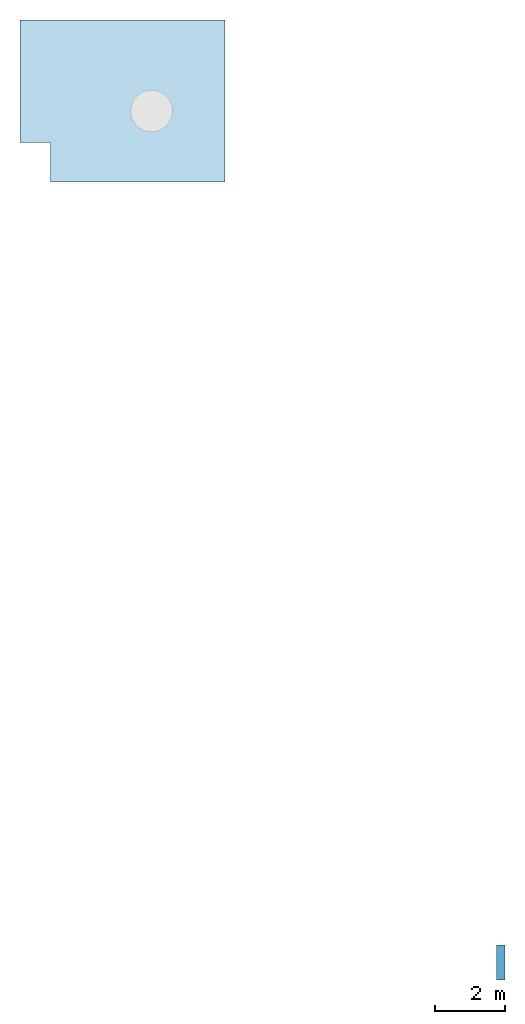
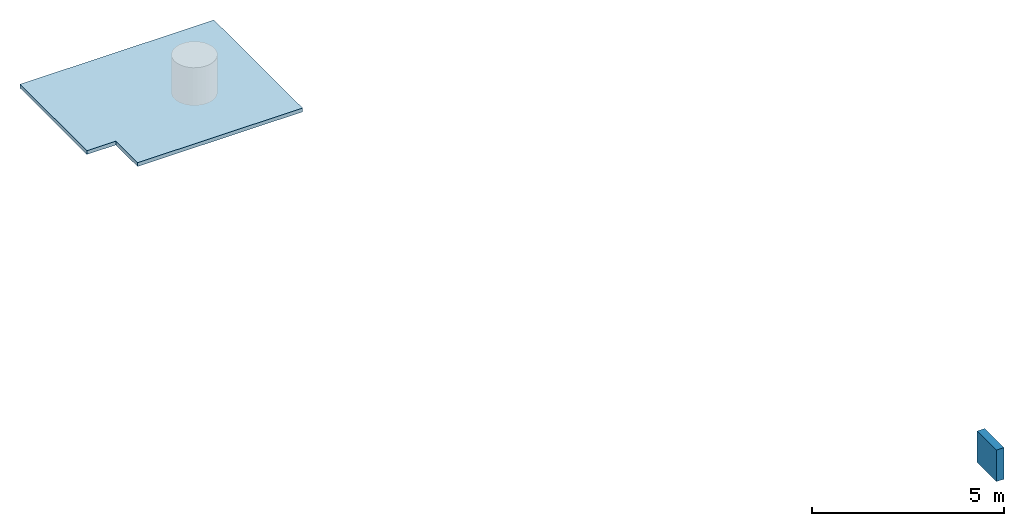
# One storey, part 1 of 2: 1 slab, 1 wall.
"""IFC4X3_ADD2 building model written with IfcOpenShell, lengths in metres."""

import ifcopenshell
import ifcopenshell.guid

model = None  # the IFC model being written
_history = None  # IfcOwnerHistory: only IFC2X3 demands one
_inside = {}  # id of a spatial element -> (the spatial element, [elements in it])
_under = {}  # id of a project, library or spatial element -> (it, [spatial elements below it])
_declared = {}  # id of a project -> (the project, [libraries it declares])
_typed = {}  # id of a type object -> (the type object, [elements of that type])
_made_of = {}  # id of a material, layer set ... -> (it, [elements and type objects made of it])


def new_model(schema):
    """Start an empty IFC model of exactly this schema.

    Asked for "IFC4X3", IfcOpenShell would pick the latest addendum, in which some entities
    have other attributes; the version numbers below select the first issue.
    IFC2X3 requires an IfcOwnerHistory on every rooted entity: one is made here for all.
    """
    global model, _history
    if schema == "IFC4X3":
        model = ifcopenshell.file(schema_version=(4, 3, 0, 0))
    else:
        model = ifcopenshell.file(schema=schema)
    _inside.clear()
    _under.clear()
    _declared.clear()
    _typed.clear()
    _made_of.clear()
    _history = None
    if model.schema == "IFC2X3":
        org = make("IfcOrganization", Name="unknown")
        user = make(
            "IfcPersonAndOrganization",
            ThePerson=make("IfcPerson", FamilyName="unknown"),
            TheOrganization=org,
        )
        app = make(
            "IfcApplication",
            ApplicationDeveloper=org,
            Version="unknown",
            ApplicationFullName="unknown",
            ApplicationIdentifier="unknown",
        )
        _history = make(
            "IfcOwnerHistory",
            OwningUser=user,
            OwningApplication=app,
            ChangeAction="ADDED",
            CreationDate=0,
        )
    return model


def make(cls, **values):
    """One entity of the class cls with the attributes given. An attribute that is None is left unset."""
    return model.create_entity(
        cls, **{name: value for name, value in values.items() if value is not None}
    )


def entity(cls, *values):
    """Any entity or typed value of the class cls, its attributes in the order of the schema. None: left unset."""
    e = model.create_entity(cls)
    for i, value in enumerate(values):
        if value is not None:
            e[i] = value
    return e


def rooted(cls, **values):
    """An entity with a GlobalId (a new one), such as an element, a storey or a relation."""
    return make(cls, GlobalId=ifcopenshell.guid.new(), OwnerHistory=_history, **values)


def si_unit(unit_type, name, prefix=None):
    """IfcSIUnit, for example si_unit("LENGTHUNIT", "METRE", prefix="MILLI")."""
    return make("IfcSIUnit", UnitType=unit_type, Prefix=prefix, Name=name)


def converted_unit(unit_type, name, factor, base, dimensions=None, offset=None):
    """IfcConversionBasedUnit, such as the inch: factor (a typed value) times the base unit."""
    return make(
        "IfcConversionBasedUnit"
        if offset is None
        else "IfcConversionBasedUnitWithOffset",
        ConversionOffset=offset,
        Dimensions=None
        if dimensions is None
        else entity("IfcDimensionalExponents", *dimensions),
        UnitType=unit_type,
        Name=name,
        ConversionFactor=make(
            "IfcMeasureWithUnit", ValueComponent=factor, UnitComponent=base
        ),
    )


def assignment(units):
    """IfcUnitAssignment: the units of a project."""
    return None if units is None else make("IfcUnitAssignment", Units=units)


def point(xyz):
    """IfcCartesianPoint."""
    return None if xyz is None else make("IfcCartesianPoint", Coordinates=xyz)


def direction(xyz):
    """IfcDirection."""
    return None if xyz is None else make("IfcDirection", DirectionRatios=xyz)


def frame(location, z_axis=None, x_axis=None):
    """IfcAxis2Placement3D, a coordinate frame: its origin and axes. An axis left out is left unset."""
    return make(
        "IfcAxis2Placement3D",
        Location=point(location),
        Axis=direction(z_axis),
        RefDirection=direction(x_axis),
    )


def frame_2d(location, x_axis=None):
    """IfcAxis2Placement2D, a coordinate frame in the plane: its origin and x axis."""
    return make(
        "IfcAxis2Placement2D", Location=point(location), RefDirection=direction(x_axis)
    )


def origin_with_axes():
    """The frame at (0, 0, 0) with the z axis (0, 0, 1) and the x axis (1, 0, 0) written out."""
    return frame((0.0, 0.0, 0.0), z_axis=(0.0, 0.0, 1.0), x_axis=(1.0, 0.0, 0.0))


def origin_2d_with_axis():
    """The frame at (0, 0) in the plane with the x axis (1, 0) written out."""
    return frame_2d((0.0, 0.0), x_axis=(1.0, 0.0))


def place(relative_to, where):
    """IfcLocalPlacement: puts the frame where relative to a parent placement (None: the world)."""
    return make(
        "IfcLocalPlacement", PlacementRelTo=relative_to, RelativePlacement=where
    )


def context(
    kind, dimensions, precision=None, world=None, true_north=None, identifier=None
):
    """IfcGeometricRepresentationContext, for example the 3D "Model" context."""
    return make(
        "IfcGeometricRepresentationContext",
        ContextIdentifier=identifier,
        ContextType=kind,
        CoordinateSpaceDimension=dimensions,
        Precision=precision,
        WorldCoordinateSystem=world,
        TrueNorth=true_north,
    )


def subcontext(parent, identifier, kind, view, scale=None):
    """IfcGeometricRepresentationSubContext, for example "Body" below "Model"."""
    return make(
        "IfcGeometricRepresentationSubContext",
        ContextIdentifier=identifier,
        ContextType=kind,
        ParentContext=parent,
        TargetScale=scale,
        TargetView=view,
    )


def project(units=None, contexts=None):
    """IfcProject with its units and contexts."""
    return rooted(
        "IfcProject",
        Name="project",
        RepresentationContexts=contexts,
        UnitsInContext=assignment(units),
    )


def spatial(cls, under=None, at=None, **own):
    """A site, building, storey or space (cls), placed at a placement, below another one or the project."""
    s = rooted(cls, ObjectPlacement=at, **own)
    if under is not None:
        _under.setdefault(under.id(), (under, []))[1].append(s)
    return s


def point_list(points):
    """IfcCartesianPointList2D or 3D."""
    cls = (
        "IfcCartesianPointList2D" if len(points[0]) == 2 else "IfcCartesianPointList3D"
    )
    return make(cls, CoordList=points)


def line(*indices):
    """IfcLineIndex: a straight run through numbered points of an indexed curve."""
    return model.create_entity("IfcLineIndex", indices)


def indexed_curve(points, segments=None, self_intersect=None):
    """IfcIndexedPolyCurve: lines and arcs through numbered points (the first is 1)."""
    return make(
        "IfcIndexedPolyCurve",
        Points=point_list(points),
        Segments=segments,
        SelfIntersect=self_intersect,
    )


def outline(outer, holes=None, kind="AREA"):
    """IfcArbitraryClosedProfileDef: a profile drawn as a closed curve; with holes, ...WithVoids."""
    if holes is None:
        return make("IfcArbitraryClosedProfileDef", ProfileType=kind, OuterCurve=outer)
    return make(
        "IfcArbitraryProfileDefWithVoids",
        ProfileType=kind,
        OuterCurve=outer,
        InnerCurves=holes,
    )


def extrude(swept, where, along, depth):
    """IfcExtrudedAreaSolid: the profile swept, set in the frame where, extruded along a direction by depth."""
    return make(
        "IfcExtrudedAreaSolid",
        SweptArea=swept,
        Position=where,
        ExtrudedDirection=direction(along),
        Depth=depth,
    )


def shape(context_of_items, identifier, shape_type, items):
    """IfcShapeRepresentation: the items that make up one representation, for example the "Body"."""
    return make(
        "IfcShapeRepresentation",
        ContextOfItems=context_of_items,
        RepresentationIdentifier=identifier,
        RepresentationType=shape_type,
        Items=items,
    )


def material(Name=None, Category=None):
    """IfcMaterial."""
    return make("IfcMaterial", Name=Name, Category=Category)


def layer(
    of_material, thickness, ventilated=None, Name=None, Category=None, Priority=None
):
    """IfcMaterialLayer: one layer of a wall or slab, of a material (None: an air gap)."""
    return make(
        "IfcMaterialLayer",
        Material=of_material,
        LayerThickness=thickness,
        IsVentilated=ventilated,
        Name=Name,
        Category=Category,
        Priority=Priority,
    )


def layer_set(layers, Name=None):
    """IfcMaterialLayerSet."""
    return make("IfcMaterialLayerSet", MaterialLayers=layers, LayerSetName=Name)


def layer_usage(for_layer_set, set_direction, sense, offset, extent=None):
    """IfcMaterialLayerSetUsage: how a layer set lies in its element."""
    return make(
        "IfcMaterialLayerSetUsage",
        ForLayerSet=for_layer_set,
        LayerSetDirection=set_direction,
        DirectionSense=sense,
        OffsetFromReferenceLine=offset,
        ReferenceExtent=extent,
    )


def made_of(thing, what):
    """Note that an element or type object is made of a material, layer set ...; save() writes the relation."""
    if what is not None:
        _made_of.setdefault(what.id(), (what, []))[1].append(thing)
    return thing


def type_object(cls, material=None, **own):
    """A type object (cls), such as IfcWallType, which elements share."""
    return made_of(rooted(cls, **own), material)


def element(
    cls,
    number,
    at=None,
    inside=None,
    cuts=None,
    type_object=None,
    material=None,
    context=None,
    identifier="Body",
    shape_type=None,
    held_by="IfcProductDefinitionShape",
    body=None,
    shapes=None,
    **own,
):
    """One element of the class cls, such as IfcWall. Its Tag is "e" and its number.

    at: its placement. inside: the storey or other place that contains it. cuts: it is an
    opening in that element (IfcRelVoidsElement). A single representation is given by context,
    identifier, shape_type and body (its items); several are given by shapes. held_by: the class
    of the entity that holds the representations. save() writes the other relations.
    """
    e = rooted(cls, Tag="e%d" % number, ObjectPlacement=at, **own)
    if body is not None:
        shapes = [shape(context, identifier, shape_type, body)]
    if shapes is not None:
        e.Representation = make(held_by, Representations=shapes)
    if inside is not None:
        _inside.setdefault(inside.id(), (inside, []))[1].append(e)
    if cuts is not None:
        rooted(
            "IfcRelVoidsElement", RelatingBuildingElement=cuts, RelatedOpeningElement=e
        )
    if type_object is not None:
        _typed.setdefault(type_object.id(), (type_object, []))[1].append(e)
    return made_of(e, material)


def aggregate(whole, parts):
    """IfcRelAggregates: a whole, such as a stair, and the parts it consists of."""
    return rooted("IfcRelAggregates", RelatingObject=whole, RelatedObjects=parts)


def save(model, path):
    """Write the relations noted so far, then the file.

    IfcRelAggregates (storeys below a building ...), IfcRelContainedInSpatialStructure (elements
    in a storey), IfcRelDefinesByType, IfcRelAssociatesMaterial and IfcRelDeclares: one each for
    every whole, place, type object, material and project.
    """
    for whole, parts in _under.values():
        aggregate(whole, parts)
    for where, things in _inside.values():
        rooted(
            "IfcRelContainedInSpatialStructure",
            RelatedElements=things,
            RelatingStructure=where,
        )
    for kind, things in _typed.values():
        rooted("IfcRelDefinesByType", RelatedObjects=things, RelatingType=kind)
    for what, things in _made_of.values():
        rooted("IfcRelAssociatesMaterial", RelatedObjects=things, RelatingMaterial=what)
    for by, libraries in _declared.values():
        rooted("IfcRelDeclares", RelatingContext=by, RelatedDefinitions=libraries)
    model.write(path)


model = new_model("IFC4X3_ADD2")

# Units and contexts
model_context = context("Model", 3, precision=1e-05, world=origin_with_axes())
plan_context = context("Plan", 2, precision=1e-05, world=origin_2d_with_axis())
body_context = subcontext(model_context, "Body", "Model", "MODEL_VIEW")
ifc_project = project(units=[si_unit("VOLUMEUNIT", "CUBIC_METRE"), si_unit("LENGTHUNIT", "METRE"), converted_unit("PLANEANGLEUNIT", "degree", entity("IfcReal", 0.0174532925199433), si_unit("PLANEANGLEUNIT", "RADIAN"), dimensions=[0, 0, 0, 0, 0, 0, 0]), si_unit("AREAUNIT", "SQUARE_METRE")], contexts=[model_context, plan_context])

# Site, building, storey
site_placement = place(None, origin_with_axes())
site = spatial("IfcSite", under=ifc_project, at=site_placement)
building_placement = place(site_placement, origin_with_axes())
building = spatial("IfcBuilding", under=site, at=building_placement, Name="Building")
storey_placement = place(building_placement, frame((0.0, 0.0, 5.69999980926514), z_axis=(0.0, 0.0, 1.0), x_axis=(1.0, 0.0, 0.0)))
storey = spatial("IfcBuildingStorey", under=building, at=storey_placement)

# Slab
ifc_material_1 = material(Name="Concrete")
ifc_layer_1 = layer(ifc_material_1, 0.119999997317791)
ifc_layer_set_1 = layer_set([ifc_layer_1])
ifc_layer_usage_1 = layer_usage(ifc_layer_set_1, "AXIS3", "POSITIVE", 0.0)
slab_type = type_object("IfcSlabType", Name="Concrete 100mm", PredefinedType="FLOOR", material=ifc_layer_set_1)
slab_placement = place(storey_placement, frame((19.1950168609619, 21.2454051971436, 0.690000057220455), z_axis=(0.0, 0.0, 1.0), x_axis=(1.0, 0.0, 0.0)))
element("IfcSlab", 1, at=slab_placement, inside=storey, type_object=slab_type, material=ifc_layer_usage_1, Name="Slab", context=body_context, shape_type="SweptSolid", body=[
    extrude(outline(indexed_curve([(5.57279777526855, -2.12751197814941), (0.617390513420105, -2.12751197814941), (0.617390513420105, -0.997512817382812), (-0.250001907348633, -0.997512817382812), (-0.250001907348633, 2.48248672485352), (5.57279777526855, 2.48248672485352), (5.57279777526855, -0.997512817382812), (5.57279777526855, -2.12751197814941)])), None, (0.0, 0.0, 1.0), 0.119999997317791),
])

# Wall
ifc_material_2 = material(Name="Wall")
ifc_layer_2 = layer(ifc_material_2, 0.230000004172325)
ifc_layer_set_2 = layer_set([ifc_layer_2], Name="brick")
ifc_layer_usage_2 = layer_usage(ifc_layer_set_2, "AXIS2", "POSITIVE", 0.0)
wall_type = type_object("IfcWallType", Name="Wall 230mm", PredefinedType="SOLIDWALL", material=ifc_layer_set_2)
wall_placement = place(storey_placement, frame((32.4986534118652, -2.56703209877014, -3.5527136788005e-15), z_axis=(0.0, 0.0, 1.0), x_axis=(-4.37113882867379e-08, -0.999999999999999, 0.0)))
element("IfcWall", 2, at=wall_placement, inside=storey, type_object=wall_type, material=ifc_layer_usage_2, Name="Wall", context=body_context, shape_type="SweptSolid", body=[
    extrude(outline(indexed_curve([(0.0, 0.0), (0.0, 0.230000004172325), (1.0, 0.230000004172325), (1.0, 0.0)], segments=[line(1, 2, 3, 4, 1)])), origin_with_axes(), (0.0, 0.0, 1.0), 1.0),
])

save(model, "model.ifc")
